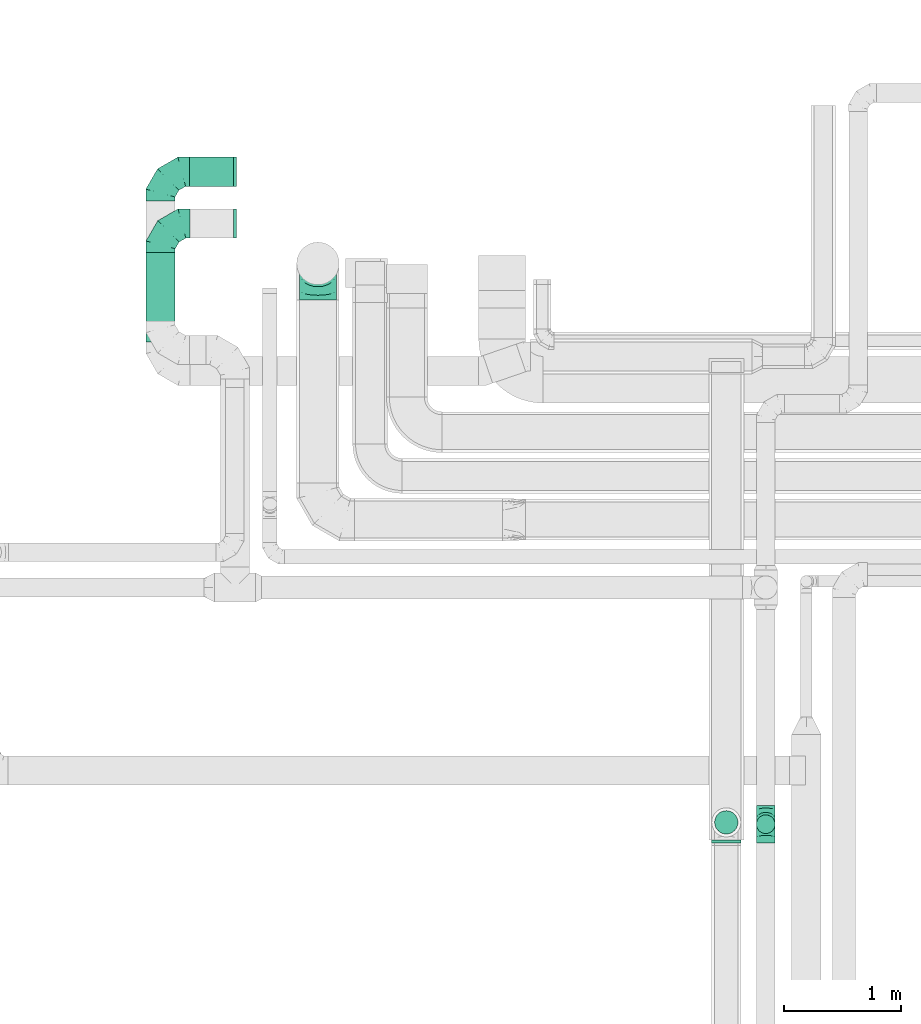
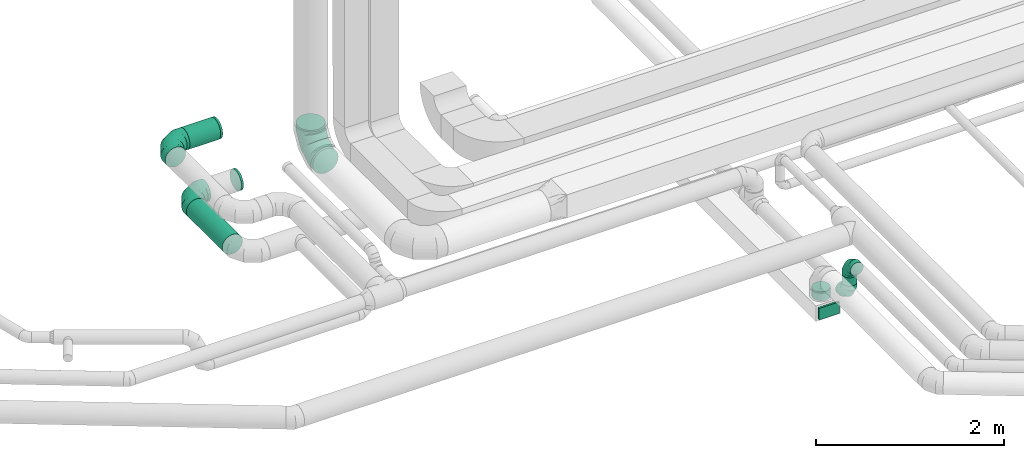
# One storey, part 37 of 92: 8 flow fittings, 4 flow segments.
"""IFC2X3 building model written with IfcOpenShell, lengths in millimetres."""

from ifc_helpers import new_model, entity, si_unit, converted_unit, derived_unit, direction, frame, origin, origin_2d_with_axis, place, context, subcontext, project, spatial, rectangle, circle, extrude, faceted_brep, source, transform, mapped, material, type_object, type_shapes, element, save


model = new_model("IFC2X3")

# Units and contexts
model_context = context("Model", 3, precision=0.01, world=origin(), true_north=direction((6.12303176911189e-17, 1.0)))
body_context = subcontext(model_context, "Body", "Model", "MODEL_VIEW")
ifc_project = project(units=[si_unit("LENGTHUNIT", "METRE", prefix="MILLI"), si_unit("AREAUNIT", "SQUARE_METRE"), si_unit("VOLUMEUNIT", "CUBIC_METRE"), converted_unit("PLANEANGLEUNIT", "DEGREE", entity("IfcRatioMeasure", 0.0174532925199433), si_unit("PLANEANGLEUNIT", "RADIAN"), dimensions=[0, 0, 0, 0, 0, 0, 0]), si_unit("MASSUNIT", "GRAM", prefix="KILO"), derived_unit("MASSDENSITYUNIT", [(si_unit("MASSUNIT", "GRAM", prefix="KILO"), 1), (si_unit("LENGTHUNIT", "METRE"), -3)]), derived_unit("MOMENTOFINERTIAUNIT", [(si_unit("LENGTHUNIT", "METRE"), 4)]), si_unit("TIMEUNIT", "SECOND"), si_unit("FREQUENCYUNIT", "HERTZ"), si_unit("THERMODYNAMICTEMPERATUREUNIT", "DEGREE_CELSIUS"), derived_unit("THERMALTRANSMITTANCEUNIT", [(si_unit("MASSUNIT", "GRAM", prefix="KILO"), 1), (si_unit("THERMODYNAMICTEMPERATUREUNIT", "KELVIN"), -1), (si_unit("TIMEUNIT", "SECOND"), -3)]), derived_unit("VOLUMETRICFLOWRATEUNIT", [(si_unit("LENGTHUNIT", "METRE"), 3), (si_unit("TIMEUNIT", "SECOND"), -1)]), derived_unit("MASSFLOWRATEUNIT", [(si_unit("MASSUNIT", "GRAM", prefix="KILO"), 1), (si_unit("TIMEUNIT", "SECOND"), -1)]), derived_unit("ROTATIONALFREQUENCYUNIT", [(si_unit("TIMEUNIT", "SECOND"), -1)]), si_unit("ELECTRICCURRENTUNIT", "AMPERE"), si_unit("ELECTRICVOLTAGEUNIT", "VOLT"), si_unit("POWERUNIT", "WATT"), si_unit("FORCEUNIT", "NEWTON", prefix="KILO"), si_unit("ILLUMINANCEUNIT", "LUX"), si_unit("LUMINOUSFLUXUNIT", "LUMEN"), si_unit("LUMINOUSINTENSITYUNIT", "CANDELA"), derived_unit("USERDEFINED", [(si_unit("MASSUNIT", "GRAM", prefix="KILO"), -1), (si_unit("LENGTHUNIT", "METRE"), -2), (si_unit("TIMEUNIT", "SECOND"), 3), (si_unit("LUMINOUSFLUXUNIT", "LUMEN"), 1)]), derived_unit("LINEARVELOCITYUNIT", [(si_unit("LENGTHUNIT", "METRE"), 1), (si_unit("TIMEUNIT", "SECOND"), -1)]), si_unit("PRESSUREUNIT", "PASCAL"), derived_unit("USERDEFINED", [(si_unit("LENGTHUNIT", "METRE"), -2), (si_unit("MASSUNIT", "GRAM", prefix="KILO"), 1), (si_unit("TIMEUNIT", "SECOND"), -2)]), derived_unit("LINEARFORCEUNIT", [(si_unit("MASSUNIT", "GRAM", prefix="KILO"), 1), (si_unit("LENGTHUNIT", "METRE"), 1), (si_unit("TIMEUNIT", "SECOND"), -2), (si_unit("LENGTHUNIT", "METRE"), -1)]), derived_unit("PLANARFORCEUNIT", [(si_unit("MASSUNIT", "GRAM", prefix="KILO"), 1), (si_unit("LENGTHUNIT", "METRE"), 1), (si_unit("TIMEUNIT", "SECOND"), -2), (si_unit("LENGTHUNIT", "METRE"), -2)])], contexts=[model_context])

# Site, building, storey
site_placement = place(None, origin())
site = spatial("IfcSite", under=ifc_project, at=site_placement, CompositionType="ELEMENT")
building_placement = place(site_placement, origin())
building = spatial("IfcBuilding", under=site, at=building_placement, CompositionType="ELEMENT")
storey_placement = place(building_placement, frame((0.0, 0.0, 4200.0)))
storey = spatial("IfcBuildingStorey", under=building, at=storey_placement, CompositionType="ELEMENT", Elevation=4200.0)

# Flow segments
duct_segment_type = type_object("IfcDuctSegmentType", PredefinedType="NOTDEFINED")
flow_segment_1_placement = place(storey_placement, frame((7500.09, 14677.34, 3173.4)))
element("IfcFlowSegment", 1, at=flow_segment_1_placement, inside=storey, type_object=duct_segment_type, context=body_context, shape_type="SweptSolid", body=[
    extrude(circle(Radius=125.0, at=origin_2d_with_axis()), frame((0.0, 126.6, 126.6), z_axis=(1.0, 0.0, 0.0), x_axis=(0.0, -1.0, 0.0)), (0.0, 0.0, 1.0), 378.447854444327),
])
flow_segment_2_placement = place(storey_placement, frame((7125.2, 13345.03, 2773.4)))
element("IfcFlowSegment", 2, at=flow_segment_2_placement, inside=storey, type_object=duct_segment_type, context=body_context, shape_type="SweptSolid", body=[
    extrude(circle(Radius=125.0, at=origin_2d_with_axis()), frame((126.6, 0.0, 126.6), z_axis=(0.0, 1.0, 0.0), x_axis=(-1.0, 0.0, 0.0)), (0.0, 0.0, 1.0), 764.599999999878),
])
flow_segment_3_placement = place(storey_placement, frame((12361.42, 9125.19, 3100.0)))
element("IfcFlowSegment", 3, at=flow_segment_3_placement, inside=storey, type_object=duct_segment_type, context=body_context, shape_type="SweptSolid", body=[
    extrude(circle(Radius=80.0, at=origin_2d_with_axis()), frame((81.6, 81.6, 0.0), z_axis=(0.0, 0.0, 1.0), x_axis=(-1.0, 0.0, 0.0)), (0.0, 0.0, 1.0), 109.999999999369),
])
flow_segment_4_placement = place(storey_placement, frame((12002.68, 9120.9, 3035.0)))
element("IfcFlowSegment", 4, at=flow_segment_4_placement, inside=storey, type_object=duct_segment_type, context=body_context, shape_type="SweptSolid", body=[
    extrude(circle(Radius=100.0, at=origin_2d_with_axis()), frame((101.6, 101.6, 0.0)), (0.0, 0.0, 1.0), 115.00000000001),
])

# Flow fittings
ifc_material = material()
duct_fitting_type_1 = type_object("IfcDuctFittingType", PredefinedType="NOTDEFINED", material=ifc_material)
shared_shape_1 = source(origin(), body_context, "Body", "SweptSolid", [
    extrude(rectangle(XDim=24.9999999999999, YDim=250.0, at=origin_2d_with_axis()), frame((12.5, 0.0, -75.0)), (0.0, 0.0, 1.0), 150.0),
])
type_shapes(duct_fitting_type_1, [shared_shape_1])
flow_fitting_1_placement = place(storey_placement, frame((12104.27, 9071.64, 2940.0), z_axis=(0.0, 0.0, 1.0), x_axis=(0.0, -1.0, 0.0)))
element("IfcFlowFitting", 5, at=flow_fitting_1_placement, inside=storey, type_object=duct_fitting_type_1, material=ifc_material, context=body_context, shape_type="MappedRepresentation", body=[
    mapped(shared_shape_1, transform((0.0, 0.0, 0.0), scale=1.0)),
])
duct_fitting_type_2 = type_object("IfcDuctFittingType", PredefinedType="NOTDEFINED", material=ifc_material)
shared_shape_2 = source(origin(), body_context, "Body", "Brep", [
    faceted_brep([(-160.0, 0.0, -80.0), (-160.0, -20.71, -77.27), (-160.0, -40.0, -69.28), (-160.0, -56.57, -56.57), (-160.0, -69.28, -40.0), (-160.0, -77.27, -20.71), (-160.0, -80.0, 0.0), (-160.0, -77.27, 20.71), (-160.0, -69.28, 40.0), (-160.0, -56.57, 56.57), (-160.0, -40.0, 69.28), (-160.0, -20.71, 77.27), (-160.0, 0.0, 80.0), (-160.0, 20.71, 77.27), (-160.0, 40.0, 69.28), (-160.0, 56.57, 56.57), (-160.0, 69.28, 40.0), (-160.0, 77.27, 20.71), (-160.0, 80.0, 0.0), (-160.0, 77.27, -20.71), (-160.0, 69.28, -40.0), (-160.0, 56.57, -56.57), (-160.0, 40.0, -69.28), (-160.0, 20.71, -77.27), (-122.68, 20.71, 77.27), (-127.85, 40.0, 69.28), (-117.13, 0.0, 80.0), (-132.29, 56.57, 56.57), (-137.83, 77.27, 20.71), (-138.56, 80.0, 0.0), (-135.69, 69.28, 40.0), (-135.69, 69.28, -40.0), (-132.29, 56.57, -56.57), (-137.83, 77.27, -20.71), (-122.68, 20.71, -77.27), (-117.13, 0.0, -80.0), (-127.85, 40.0, -69.28), (-111.58, -20.71, -77.27), (-106.41, -40.0, -69.28), (-101.97, -56.57, -56.57), (-98.56, -69.28, -40.0), (-96.42, -77.27, -20.71), (-95.69, -80.0, 0.0), (-96.42, -77.27, 20.71), (-98.56, -69.28, 40.0), (-101.97, -56.57, 56.57), (-106.41, -40.0, 69.28), (-111.58, -20.71, 77.27), (-58.03, 58.03, 77.27), (-72.15, 72.15, 69.28), (-42.87, 42.87, 80.0), (-84.28, 84.28, 56.57), (-93.59, 93.59, 40.0), (-99.44, 99.44, 20.71), (-101.44, 101.44, 0.0), (-99.44, 99.44, -20.71), (-93.59, 93.59, -40.0), (-84.28, 84.28, -56.57), (-58.03, 58.03, -77.27), (-42.87, 42.87, -80.0), (-72.15, 72.15, -69.28), (-27.71, 27.71, -77.27), (-13.59, 13.59, -69.28), (-1.46, 1.46, -56.57), (7.85, -7.85, -40.0), (13.7, -13.7, -20.71), (15.69, -15.69, 0.0), (13.7, -13.7, 20.71), (7.85, -7.85, 40.0), (-1.46, 1.46, 56.57), (-13.59, 13.59, 69.28), (-27.71, 27.71, 77.27), (-20.71, 122.68, 77.27), (-40.0, 127.85, 69.28), (0.0, 117.13, 80.0), (-56.57, 132.29, 56.57), (-69.28, 135.69, 40.0), (-77.27, 137.83, 20.71), (-80.0, 138.56, 0.0), (-77.27, 137.83, -20.71), (-69.28, 135.69, -40.0), (-56.57, 132.29, -56.57), (-20.71, 122.68, -77.27), (0.0, 117.13, -80.0), (-40.0, 127.85, -69.28), (20.71, 111.58, -77.27), (40.0, 106.41, -69.28), (56.57, 101.97, -56.57), (69.28, 98.56, -40.0), (77.27, 96.42, -20.71), (80.0, 95.69, 0.0), (77.27, 96.42, 20.71), (69.28, 98.56, 40.0), (56.57, 101.97, 56.57), (40.0, 106.41, 69.28), (20.71, 111.58, 77.27), (-20.71, 160.0, -77.27), (-40.0, 160.0, -69.28), (-56.57, 160.0, -56.57), (-69.28, 160.0, -40.0), (-77.27, 160.0, -20.71), (-80.0, 160.0, 0.0), (-77.27, 160.0, 20.71), (-69.28, 160.0, 40.0), (-56.57, 160.0, 56.57), (-40.0, 160.0, 69.28), (-20.71, 160.0, 77.27), (0.0, 160.0, 80.0), (20.71, 160.0, 77.27), (40.0, 160.0, 69.28), (56.57, 160.0, 56.57), (69.28, 160.0, 40.0), (77.27, 160.0, 20.71), (80.0, 160.0, 0.0), (77.27, 160.0, -20.71), (69.28, 160.0, -40.0), (56.57, 160.0, -56.57), (40.0, 160.0, -69.28), (20.71, 160.0, -77.27), (0.0, 160.0, -80.0)], [[[0, 1, 2, 3, 4, 5, 6, 7, 8, 9, 10, 11, 12, 13, 14, 15, 16, 17, 18, 19, 20, 21, 22, 23]], [[24, 25, 14, 13]], [[26, 24, 13, 12]], [[14, 25, 27, 15]], [[28, 29, 18, 17]], [[30, 28, 17, 16]], [[15, 27, 30, 16]], [[20, 31, 32, 21]], [[33, 31, 20, 19]], [[18, 29, 33, 19]], [[34, 35, 0, 23]], [[36, 34, 23, 22]], [[32, 36, 22, 21]], [[1, 0, 35, 37]], [[2, 1, 37, 38]], [[3, 2, 38, 39]], [[5, 4, 40, 41]], [[6, 5, 41, 42]], [[39, 40, 4, 3]], [[6, 42, 43, 7]], [[7, 43, 44, 8]], [[8, 44, 45, 9]], [[9, 45, 46, 10]], [[10, 46, 47, 11]], [[26, 12, 11, 47]], [[48, 49, 25, 24]], [[50, 48, 24, 26]], [[27, 25, 49, 51]], [[52, 53, 28, 30]], [[51, 52, 30, 27]], [[29, 28, 53, 54]], [[55, 56, 31, 33]], [[54, 55, 33, 29]], [[32, 31, 56, 57]], [[58, 59, 35, 34]], [[60, 58, 34, 36]], [[57, 60, 36, 32]], [[37, 35, 59, 61]], [[38, 37, 61, 62]], [[39, 38, 62, 63]], [[41, 40, 64, 65]], [[42, 41, 65, 66]], [[63, 64, 40, 39]], [[43, 42, 66, 67]], [[44, 43, 67, 68]], [[68, 69, 45, 44]], [[46, 45, 69, 70]], [[47, 46, 70, 71]], [[26, 47, 71, 50]], [[72, 73, 49, 48]], [[74, 72, 48, 50]], [[51, 49, 73, 75]], [[76, 77, 53, 52]], [[75, 76, 52, 51]], [[54, 53, 77, 78]], [[79, 80, 56, 55]], [[78, 79, 55, 54]], [[57, 56, 80, 81]], [[82, 83, 59, 58]], [[84, 82, 58, 60]], [[81, 84, 60, 57]], [[61, 59, 83, 85]], [[62, 61, 85, 86]], [[63, 62, 86, 87]], [[65, 64, 88, 89]], [[66, 65, 89, 90]], [[87, 88, 64, 63]], [[67, 66, 90, 91]], [[68, 67, 91, 92]], [[92, 93, 69, 68]], [[70, 69, 93, 94]], [[71, 70, 94, 95]], [[50, 71, 95, 74]], [[96, 97, 98, 99, 100, 101, 102, 103, 104, 105, 106, 107, 108, 109, 110, 111, 112, 113, 114, 115, 116, 117, 118, 119]], [[72, 74, 107, 106]], [[73, 72, 106, 105]], [[75, 73, 105, 104]], [[77, 76, 103, 102]], [[78, 77, 102, 101]], [[75, 104, 103, 76]], [[78, 101, 100, 79]], [[79, 100, 99, 80]], [[80, 99, 98, 81]], [[84, 97, 96, 82]], [[82, 96, 119, 83]], [[84, 81, 98, 97]], [[118, 117, 86, 85]], [[119, 118, 85, 83]], [[116, 87, 86, 117]], [[88, 115, 114, 89]], [[89, 114, 113, 90]], [[115, 88, 87, 116]], [[112, 111, 92, 91]], [[113, 112, 91, 90]], [[111, 110, 93, 92]], [[95, 94, 109, 108]], [[74, 95, 108, 107]], [[110, 109, 94, 93]]]),
])
type_shapes(duct_fitting_type_2, [shared_shape_2])
for number, where, z_axis, x_axis in (
    (6, (12443.02, 9206.78, 3370.0), (1.0, 0.0, 0.0), (0.0, 0.0, 1.0)),
    (7, (12443.02, 9206.78, 2940.0), (1.0, 0.0, 0.0), (0.0, 0.0, -1.0)),
):
    element("IfcFlowFitting", number, at=place(storey_placement, frame(where, z_axis=z_axis, x_axis=x_axis)), inside=storey, type_object=duct_fitting_type_2, material=ifc_material, context=body_context, shape_type="MappedRepresentation", body=[
        mapped(shared_shape_2, transform((0.0, 0.0, 0.0), scale=1.0)),
    ])
duct_fitting_type_3 = type_object("IfcDuctFittingType", PredefinedType="NOTDEFINED", material=ifc_material)
shared_shape_3 = source(origin(), body_context, "Body", "Brep", [
    faceted_brep([(-250.0, 0.0, -125.0), (-250.0, -32.35, -120.74), (-250.0, -62.5, -108.25), (-250.0, -88.39, -88.39), (-250.0, -108.25, -62.5), (-250.0, -120.74, -32.35), (-250.0, -125.0, 0.0), (-250.0, -120.74, 32.35), (-250.0, -108.25, 62.5), (-250.0, -88.39, 88.39), (-250.0, -62.5, 108.25), (-250.0, -32.35, 120.74), (-250.0, 0.0, 125.0), (-250.0, 32.35, 120.74), (-250.0, 62.5, 108.25), (-250.0, 88.39, 88.39), (-250.0, 108.25, 62.5), (-250.0, 120.74, 32.35), (-250.0, 125.0, 0.0), (-250.0, 120.74, -32.35), (-250.0, 108.25, -62.5), (-250.0, 88.39, -88.39), (-250.0, 62.5, -108.25), (-250.0, 32.35, -120.74), (-191.68, 32.35, 120.74), (-199.76, 62.5, 108.25), (-183.01, 0.0, 125.0), (-206.7, 88.39, 88.39), (-215.37, 120.74, 32.35), (-216.51, 125.0, 0.0), (-212.02, 108.25, 62.5), (-212.02, 108.25, -62.5), (-206.7, 88.39, -88.39), (-215.37, 120.74, -32.35), (-191.68, 32.35, -120.74), (-183.01, 0.0, -125.0), (-199.76, 62.5, -108.25), (-174.34, -32.35, -120.74), (-166.27, -62.5, -108.25), (-159.33, -88.39, -88.39), (-154.01, -108.25, -62.5), (-150.66, -120.74, -32.35), (-149.52, -125.0, 0.0), (-150.66, -120.74, 32.35), (-154.01, -108.25, 62.5), (-159.33, -88.39, 88.39), (-166.27, -62.5, 108.25), (-174.34, -32.35, 120.74), (-90.67, 90.67, 120.74), (-112.74, 112.74, 108.25), (-66.99, 66.99, 125.0), (-131.69, 131.69, 88.39), (-146.23, 146.23, 62.5), (-155.38, 155.38, 32.35), (-158.49, 158.49, 0.0), (-155.38, 155.38, -32.35), (-146.23, 146.23, -62.5), (-131.69, 131.69, -88.39), (-90.67, 90.67, -120.74), (-66.99, 66.99, -125.0), (-112.74, 112.74, -108.25), (-43.3, 43.3, -120.74), (-21.23, 21.23, -108.25), (-2.28, 2.28, -88.39), (12.26, -12.26, -62.5), (21.4, -21.4, -32.35), (24.52, -24.52, 0.0), (21.4, -21.4, 32.35), (12.26, -12.26, 62.5), (-2.28, 2.28, 88.39), (-21.23, 21.23, 108.25), (-43.3, 43.3, 120.74), (-32.35, 191.68, 120.74), (-62.5, 199.76, 108.25), (0.0, 183.01, 125.0), (-88.39, 206.7, 88.39), (-108.25, 212.02, 62.5), (-120.74, 215.37, 32.35), (-125.0, 216.51, 0.0), (-120.74, 215.37, -32.35), (-108.25, 212.02, -62.5), (-88.39, 206.7, -88.39), (-32.35, 191.68, -120.74), (0.0, 183.01, -125.0), (-62.5, 199.76, -108.25), (32.35, 174.34, -120.74), (62.5, 166.27, -108.25), (88.39, 159.33, -88.39), (108.25, 154.01, -62.5), (120.74, 150.66, -32.35), (125.0, 149.52, 0.0), (120.74, 150.66, 32.35), (108.25, 154.01, 62.5), (88.39, 159.33, 88.39), (62.5, 166.27, 108.25), (32.35, 174.34, 120.74), (-32.35, 250.0, -120.74), (-62.5, 250.0, -108.25), (-88.39, 250.0, -88.39), (-108.25, 250.0, -62.5), (-120.74, 250.0, -32.35), (-125.0, 250.0, 0.0), (-120.74, 250.0, 32.35), (-108.25, 250.0, 62.5), (-88.39, 250.0, 88.39), (-62.5, 250.0, 108.25), (-32.35, 250.0, 120.74), (0.0, 250.0, 125.0), (32.35, 250.0, 120.74), (62.5, 250.0, 108.25), (88.39, 250.0, 88.39), (108.25, 250.0, 62.5), (120.74, 250.0, 32.35), (125.0, 250.0, 0.0), (120.74, 250.0, -32.35), (108.25, 250.0, -62.5), (88.39, 250.0, -88.39), (62.5, 250.0, -108.25), (32.35, 250.0, -120.74), (0.0, 250.0, -125.0)], [[[0, 1, 2, 3, 4, 5, 6, 7, 8, 9, 10, 11, 12, 13, 14, 15, 16, 17, 18, 19, 20, 21, 22, 23]], [[24, 25, 14, 13]], [[26, 24, 13, 12]], [[14, 25, 27, 15]], [[28, 29, 18, 17]], [[30, 28, 17, 16]], [[15, 27, 30, 16]], [[20, 31, 32, 21]], [[33, 31, 20, 19]], [[18, 29, 33, 19]], [[34, 35, 0, 23]], [[36, 34, 23, 22]], [[21, 32, 36, 22]], [[1, 0, 35, 37]], [[2, 1, 37, 38]], [[38, 39, 3, 2]], [[5, 4, 40, 41]], [[6, 5, 41, 42]], [[39, 40, 4, 3]], [[6, 42, 43, 7]], [[7, 43, 44, 8]], [[8, 44, 45, 9]], [[9, 45, 46, 10]], [[10, 46, 47, 11]], [[26, 12, 11, 47]], [[48, 49, 25, 24]], [[50, 48, 24, 26]], [[27, 25, 49, 51]], [[52, 53, 28, 30]], [[51, 52, 30, 27]], [[29, 28, 53, 54]], [[55, 56, 31, 33]], [[54, 55, 33, 29]], [[32, 31, 56, 57]], [[58, 59, 35, 34]], [[60, 58, 34, 36]], [[57, 60, 36, 32]], [[37, 35, 59, 61]], [[38, 37, 61, 62]], [[39, 38, 62, 63]], [[41, 40, 64, 65]], [[42, 41, 65, 66]], [[63, 64, 40, 39]], [[43, 42, 66, 67]], [[44, 43, 67, 68]], [[68, 69, 45, 44]], [[46, 45, 69, 70]], [[47, 46, 70, 71]], [[26, 47, 71, 50]], [[72, 73, 49, 48]], [[74, 72, 48, 50]], [[51, 49, 73, 75]], [[76, 77, 53, 52]], [[75, 76, 52, 51]], [[54, 53, 77, 78]], [[79, 80, 56, 55]], [[78, 79, 55, 54]], [[57, 56, 80, 81]], [[82, 83, 59, 58]], [[84, 82, 58, 60]], [[81, 84, 60, 57]], [[61, 59, 83, 85]], [[62, 61, 85, 86]], [[63, 62, 86, 87]], [[65, 64, 88, 89]], [[66, 65, 89, 90]], [[87, 88, 64, 63]], [[67, 66, 90, 91]], [[68, 67, 91, 92]], [[92, 93, 69, 68]], [[70, 69, 93, 94]], [[71, 70, 94, 95]], [[50, 71, 95, 74]], [[96, 97, 98, 99, 100, 101, 102, 103, 104, 105, 106, 107, 108, 109, 110, 111, 112, 113, 114, 115, 116, 117, 118, 119]], [[72, 74, 107, 106]], [[73, 72, 106, 105]], [[75, 73, 105, 104]], [[77, 76, 103, 102]], [[78, 77, 102, 101]], [[75, 104, 103, 76]], [[78, 101, 100, 79]], [[79, 100, 99, 80]], [[80, 99, 98, 81]], [[84, 97, 96, 82]], [[82, 96, 119, 83]], [[84, 81, 98, 97]], [[83, 119, 118, 85]], [[85, 118, 117, 86]], [[116, 87, 86, 117]], [[88, 115, 114, 89]], [[89, 114, 113, 90]], [[115, 88, 87, 116]], [[91, 90, 113, 112]], [[92, 91, 112, 111]], [[111, 110, 93, 92]], [[95, 94, 109, 108]], [[74, 95, 108, 107]], [[110, 109, 94, 93]]]),
])
type_shapes(duct_fitting_type_3, [shared_shape_3])
for number, where, z_axis, x_axis in (
    (8, (7250.09, 14803.87, 3300.0), (0.0, 0.0, 1.0), (-1.0, 0.0, 0.0)),
    (9, (7251.8, 14359.63, 2900.0), (0.0, 0.0, 1.0), (-1.0, 0.0, 0.0)),
):
    element("IfcFlowFitting", number, at=place(storey_placement, frame(where, z_axis=z_axis, x_axis=x_axis)), inside=storey, type_object=duct_fitting_type_3, material=ifc_material, context=body_context, shape_type="MappedRepresentation", body=[
        mapped(shared_shape_3, transform((0.0, 0.0, 0.0), scale=1.0)),
    ])
duct_fitting_type_4 = type_object("IfcDuctFittingType", PredefinedType="NOTDEFINED", material=ifc_material)
shared_shape_4 = source(origin(), body_context, "Body", "Brep", [
    faceted_brep([(20.0, 32.35, -120.74), (20.0, 62.5, -108.25), (20.0, 88.39, -88.39), (20.0, 108.25, -62.5), (20.0, 120.74, -32.35), (20.0, 125.0, 0.0), (20.0, 120.74, 32.35), (20.0, 108.25, 62.5), (20.0, 88.39, 88.39), (20.0, 62.5, 108.25), (20.0, 32.35, 120.74), (20.0, 0.0, 125.0), (20.0, -32.35, 120.74), (20.0, -62.5, 108.25), (20.0, -88.39, 88.39), (20.0, -108.25, 62.5), (20.0, -120.74, 32.35), (20.0, -125.0, 0.0), (20.0, -120.74, -32.35), (20.0, -108.25, -62.5), (20.0, -88.39, -88.39), (20.0, -62.5, -108.25), (20.0, -32.35, -120.74), (20.0, 0.0, -125.0), (0.0, 0.0, 125.0), (0.0, 32.35, 120.74), (-6.1, 32.35, 120.74), (-6.1, 0.0, 125.0), (0.0, 62.5, 108.25), (-6.1, 62.5, 108.25), (0.0, 88.39, 88.39), (-6.1, 88.39, 88.39), (0.0, 108.25, 62.5), (0.0, 120.74, 32.35), (-6.1, 120.74, 32.35), (-6.1, 108.25, 62.5), (0.0, 125.0, 0.0), (-6.1, 125.0, 0.0), (0.0, 120.74, -32.35), (-6.1, 120.74, -32.35), (0.0, 108.25, -62.5), (-6.1, 108.25, -62.5), (0.0, 88.39, -88.39), (-6.1, 88.39, -88.39), (0.0, 62.5, -108.25), (0.0, 32.35, -120.74), (-6.1, 32.35, -120.74), (-6.1, 62.5, -108.25), (0.0, 0.0, -125.0), (-6.1, 0.0, -125.0), (0.0, -32.35, -120.74), (-6.1, -32.35, -120.74), (0.0, -62.5, -108.25), (-6.1, -62.5, -108.25), (0.0, -88.39, -88.39), (-6.1, -88.39, -88.39), (0.0, -108.25, -62.5), (0.0, -120.74, -32.35), (-6.1, -120.74, -32.35), (-6.1, -108.25, -62.5), (0.0, -125.0, 0.0), (-6.1, -125.0, 0.0), (0.0, -120.74, 32.35), (-6.1, -120.74, 32.35), (0.0, -108.25, 62.5), (-6.1, -108.25, 62.5), (0.0, -88.39, 88.39), (-6.1, -88.39, 88.39), (0.0, -62.5, 108.25), (0.0, -32.35, 120.74), (-6.1, -32.35, 120.74), (-6.1, -62.5, 108.25)], [[[0, 1, 2, 3, 4, 5, 6, 7, 8, 9, 10, 11, 12, 13, 14, 15, 16, 17, 18, 19, 20, 21, 22, 23]], [[24, 11, 10, 25, 26, 27]], [[25, 10, 9, 28, 29, 26]], [[28, 9, 8, 30, 31, 29]], [[32, 7, 6, 33, 34, 35]], [[33, 6, 5, 36, 37, 34]], [[30, 8, 7, 32, 35, 31]], [[36, 5, 4, 38, 39, 37]], [[38, 4, 3, 40, 41, 39]], [[40, 3, 2, 42, 43, 41]], [[44, 1, 0, 45, 46, 47]], [[45, 0, 23, 48, 49, 46]], [[42, 2, 1, 44, 47, 43]], [[48, 23, 22, 50, 51, 49]], [[50, 22, 21, 52, 53, 51]], [[52, 21, 20, 54, 55, 53]], [[56, 19, 18, 57, 58, 59]], [[57, 18, 17, 60, 61, 58]], [[54, 20, 19, 56, 59, 55]], [[60, 17, 16, 62, 63, 61]], [[62, 16, 15, 64, 65, 63]], [[64, 15, 14, 66, 67, 65]], [[68, 13, 12, 69, 70, 71]], [[69, 12, 11, 24, 27, 70]], [[66, 14, 13, 68, 71, 67]], [[49, 51, 53, 55, 59, 58, 61, 63, 65, 67, 71, 70, 27, 26, 29, 31, 35, 34, 37, 39, 41, 43, 47, 46]]]),
])
type_shapes(duct_fitting_type_4, [shared_shape_4])
flow_fitting_2_placement = place(storey_placement, frame((7898.54, 14803.94, 3300.0), z_axis=(0.0, 1.0, 0.0), x_axis=(-1.0, 0.0, 0.0)))
element("IfcFlowFitting", 10, at=flow_fitting_2_placement, inside=storey, type_object=duct_fitting_type_4, material=ifc_material, context=body_context, shape_type="MappedRepresentation", body=[
    mapped(shared_shape_4, transform((0.0, 0.0, 0.0), scale=1.0)),
])
duct_fitting_type_5 = type_object("IfcDuctFittingType", PredefinedType="NOTDEFINED", material=ifc_material)
type_shapes(duct_fitting_type_5, [shared_shape_4])
flow_fitting_3_placement = place(storey_placement, frame((7896.67, 14359.63, 2900.0), z_axis=(0.0, 1.0, 0.0), x_axis=(-1.0, 0.0, 0.0)))
element("IfcFlowFitting", 11, at=flow_fitting_3_placement, inside=storey, type_object=duct_fitting_type_5, material=ifc_material, context=body_context, shape_type="MappedRepresentation", body=[
    mapped(shared_shape_4, transform((0.0, 0.0, 0.0), scale=1.0)),
])
duct_fitting_type_6 = type_object("IfcDuctFittingType", PredefinedType="NOTDEFINED", material=ifc_material)
shared_shape_5 = source(origin(), body_context, "Body", "Brep", [
    faceted_brep([(-315.0, 0.0, -157.5), (-315.0, -40.76, -152.13), (-315.0, -78.75, -136.4), (-315.0, -111.37, -111.37), (-315.0, -136.4, -78.75), (-315.0, -152.13, -40.76), (-315.0, -157.5, 0.0), (-315.0, -152.13, 40.76), (-315.0, -136.4, 78.75), (-315.0, -111.37, 111.37), (-315.0, -78.75, 136.4), (-315.0, -40.76, 152.13), (-315.0, 0.0, 157.5), (-315.0, 40.76, 152.13), (-315.0, 78.75, 136.4), (-315.0, 111.37, 111.37), (-315.0, 136.4, 78.75), (-315.0, 152.13, 40.76), (-315.0, 157.5, 0.0), (-315.0, 152.13, -40.76), (-315.0, 136.4, -78.75), (-315.0, 111.37, -111.37), (-315.0, 78.75, -136.4), (-315.0, 40.76, -152.13), (-241.52, 40.76, 152.13), (-251.7, 78.75, 136.4), (-230.6, 0.0, 157.5), (-260.44, 111.37, 111.37), (-271.36, 152.13, 40.76), (-272.8, 157.5, 0.0), (-267.14, 136.4, 78.75), (-267.14, 136.4, -78.75), (-260.44, 111.37, -111.37), (-271.36, 152.13, -40.76), (-241.52, 40.76, -152.13), (-230.6, 0.0, -157.5), (-251.7, 78.75, -136.4), (-219.67, -40.76, -152.13), (-209.5, -78.75, -136.4), (-200.75, -111.37, -111.37), (-194.05, -136.4, -78.75), (-189.83, -152.13, -40.76), (-188.39, -157.5, 0.0), (-189.83, -152.13, 40.76), (-194.05, -136.4, 78.75), (-200.75, -111.37, 111.37), (-209.5, -78.75, 136.4), (-219.67, -40.76, 152.13), (-114.25, 114.25, 152.13), (-142.05, 142.05, 136.4), (-84.4, 84.4, 157.5), (-165.93, 165.93, 111.37), (-184.25, 184.25, 78.75), (-195.77, 195.77, 40.76), (-199.7, 199.7, 0.0), (-195.77, 195.77, -40.76), (-184.25, 184.25, -78.75), (-165.93, 165.93, -111.37), (-114.25, 114.25, -152.13), (-84.4, 84.4, -157.5), (-142.05, 142.05, -136.4), (-54.56, 54.56, -152.13), (-26.75, 26.75, -136.4), (-2.88, 2.88, -111.37), (15.45, -15.45, -78.75), (26.97, -26.97, -40.76), (30.89, -30.89, 0.0), (26.97, -26.97, 40.76), (15.45, -15.45, 78.75), (-2.88, 2.88, 111.37), (-26.75, 26.75, 136.4), (-54.56, 54.56, 152.13), (-40.76, 241.52, 152.13), (-78.75, 251.7, 136.4), (0.0, 230.6, 157.5), (-111.37, 260.44, 111.37), (-136.4, 267.14, 78.75), (-152.13, 271.36, 40.76), (-157.5, 272.8, 0.0), (-152.13, 271.36, -40.76), (-136.4, 267.14, -78.75), (-111.37, 260.44, -111.37), (-40.76, 241.52, -152.13), (0.0, 230.6, -157.5), (-78.75, 251.7, -136.4), (40.76, 219.67, -152.13), (78.75, 209.5, -136.4), (111.37, 200.75, -111.37), (136.4, 194.05, -78.75), (152.13, 189.83, -40.76), (157.5, 188.39, 0.0), (152.13, 189.83, 40.76), (136.4, 194.05, 78.75), (111.37, 200.75, 111.37), (78.75, 209.5, 136.4), (40.76, 219.67, 152.13), (-40.76, 315.0, -152.13), (-78.75, 315.0, -136.4), (-111.37, 315.0, -111.37), (-136.4, 315.0, -78.75), (-152.13, 315.0, -40.76), (-157.5, 315.0, 0.0), (-152.13, 315.0, 40.76), (-136.4, 315.0, 78.75), (-111.37, 315.0, 111.37), (-78.75, 315.0, 136.4), (-40.76, 315.0, 152.13), (0.0, 315.0, 157.5), (40.76, 315.0, 152.13), (78.75, 315.0, 136.4), (111.37, 315.0, 111.37), (136.4, 315.0, 78.75), (152.13, 315.0, 40.76), (157.5, 315.0, 0.0), (152.13, 315.0, -40.76), (136.4, 315.0, -78.75), (111.37, 315.0, -111.37), (78.75, 315.0, -136.4), (40.76, 315.0, -152.13), (0.0, 315.0, -157.5)], [[[0, 1, 2, 3, 4, 5, 6, 7, 8, 9, 10, 11, 12, 13, 14, 15, 16, 17, 18, 19, 20, 21, 22, 23]], [[24, 25, 14, 13]], [[26, 24, 13, 12]], [[14, 25, 27, 15]], [[28, 29, 18, 17]], [[30, 28, 17, 16]], [[15, 27, 30, 16]], [[20, 31, 32, 21]], [[33, 31, 20, 19]], [[18, 29, 33, 19]], [[34, 35, 0, 23]], [[36, 34, 23, 22]], [[32, 36, 22, 21]], [[1, 0, 35, 37]], [[2, 1, 37, 38]], [[38, 39, 3, 2]], [[5, 4, 40, 41]], [[6, 5, 41, 42]], [[39, 40, 4, 3]], [[6, 42, 43, 7]], [[7, 43, 44, 8]], [[8, 44, 45, 9]], [[9, 45, 46, 10]], [[10, 46, 47, 11]], [[26, 12, 11, 47]], [[48, 49, 25, 24]], [[50, 48, 24, 26]], [[27, 25, 49, 51]], [[52, 53, 28, 30]], [[51, 52, 30, 27]], [[29, 28, 53, 54]], [[55, 56, 31, 33]], [[54, 55, 33, 29]], [[32, 31, 56, 57]], [[58, 59, 35, 34]], [[60, 58, 34, 36]], [[57, 60, 36, 32]], [[37, 35, 59, 61]], [[38, 37, 61, 62]], [[39, 38, 62, 63]], [[41, 40, 64, 65]], [[42, 41, 65, 66]], [[63, 64, 40, 39]], [[43, 42, 66, 67]], [[44, 43, 67, 68]], [[68, 69, 45, 44]], [[46, 45, 69, 70]], [[47, 46, 70, 71]], [[26, 47, 71, 50]], [[72, 73, 49, 48]], [[74, 72, 48, 50]], [[51, 49, 73, 75]], [[76, 77, 53, 52]], [[75, 76, 52, 51]], [[54, 53, 77, 78]], [[79, 80, 56, 55]], [[78, 79, 55, 54]], [[57, 56, 80, 81]], [[82, 83, 59, 58]], [[84, 82, 58, 60]], [[81, 84, 60, 57]], [[61, 59, 83, 85]], [[62, 61, 85, 86]], [[63, 62, 86, 87]], [[65, 64, 88, 89]], [[66, 65, 89, 90]], [[87, 88, 64, 63]], [[67, 66, 90, 91]], [[68, 67, 91, 92]], [[92, 93, 69, 68]], [[70, 69, 93, 94]], [[71, 70, 94, 95]], [[50, 71, 95, 74]], [[96, 97, 98, 99, 100, 101, 102, 103, 104, 105, 106, 107, 108, 109, 110, 111, 112, 113, 114, 115, 116, 117, 118, 119]], [[106, 105, 73, 72]], [[107, 106, 72, 74]], [[75, 73, 105, 104]], [[77, 76, 103, 102]], [[78, 77, 102, 101]], [[104, 103, 76, 75]], [[78, 101, 100, 79]], [[79, 100, 99, 80]], [[98, 81, 80, 99]], [[84, 97, 96, 82]], [[82, 96, 119, 83]], [[97, 84, 81, 98]], [[83, 119, 118, 85]], [[85, 118, 117, 86]], [[116, 87, 86, 117]], [[88, 115, 114, 89]], [[89, 114, 113, 90]], [[115, 88, 87, 116]], [[91, 90, 113, 112]], [[92, 91, 112, 111]], [[111, 110, 93, 92]], [[95, 94, 109, 108]], [[74, 95, 108, 107]], [[110, 109, 94, 93]]]),
])
type_shapes(duct_fitting_type_6, [shared_shape_5])
flow_fitting_4_placement = place(storey_placement, frame((8601.41, 14016.72, 3292.5), z_axis=(1.0, 0.0, 0.0), x_axis=(0.0, 1.0, 0.0)))
element("IfcFlowFitting", 12, at=flow_fitting_4_placement, inside=storey, type_object=duct_fitting_type_6, material=ifc_material, context=body_context, shape_type="MappedRepresentation", body=[
    mapped(shared_shape_5, transform((0.0, 0.0, 0.0), scale=1.0)),
])

save(model, "model.ifc")
